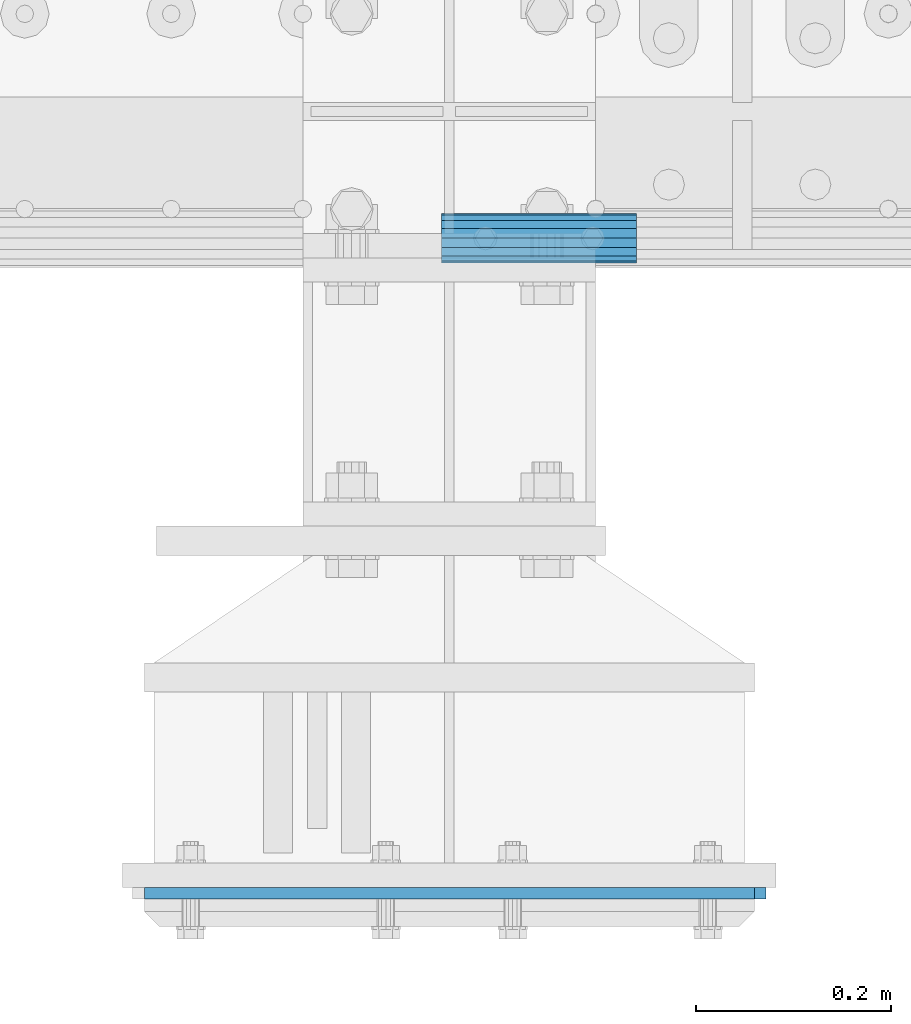
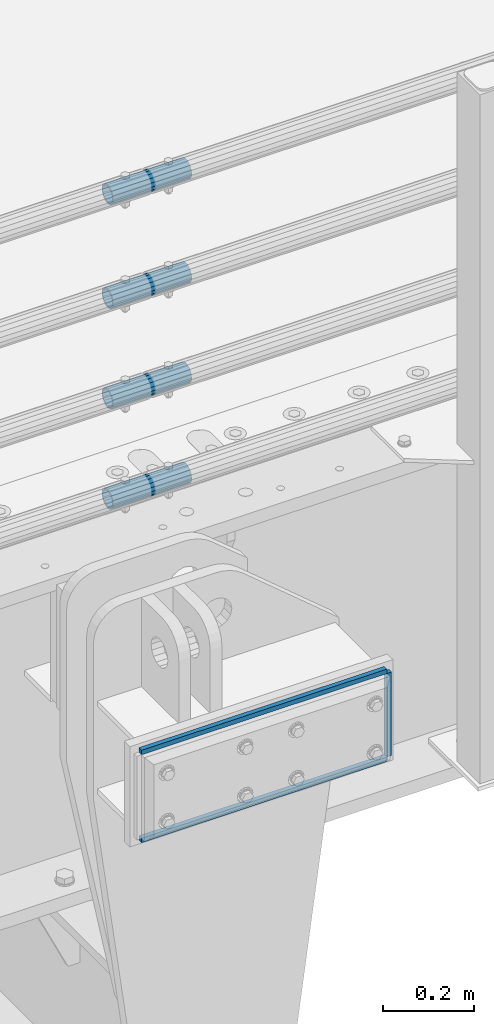
# One storey, part 157 of 270: 7 beams.
"""IFC2X3 building model written with IfcOpenShell, lengths in millimetres."""

from ifc_helpers import new_model, si_unit, frame, origin_with_axes, place, context, subcontext, project, spatial, faceted_brep, material, type_object, element, save


model = new_model("IFC2X3")

# Units and contexts
model_context = context("Model", 3, precision=1e-05, world=origin_with_axes())
body_context = subcontext(model_context, "Body", "Model", "MODEL_VIEW")
ifc_project = project(units=[si_unit("LENGTHUNIT", "METRE", prefix="MILLI"), si_unit("AREAUNIT", "SQUARE_METRE"), si_unit("VOLUMEUNIT", "CUBIC_METRE"), si_unit("MASSUNIT", "GRAM", prefix="KILO"), si_unit("TIMEUNIT", "SECOND"), si_unit("PLANEANGLEUNIT", "RADIAN"), si_unit("SOLIDANGLEUNIT", "STERADIAN"), si_unit("THERMODYNAMICTEMPERATUREUNIT", "DEGREE_CELSIUS"), si_unit("LUMINOUSINTENSITYUNIT", "LUMEN")], contexts=[model_context])

# Site, building, storey
site_placement = place(None, origin_with_axes())
site = spatial("IfcSite", under=ifc_project, at=site_placement, CompositionType="ELEMENT")
building_placement = place(site_placement, origin_with_axes())
building = spatial("IfcBuilding", under=site, at=building_placement, Name="Standard", CompositionType="ELEMENT")
storey_placement = place(building_placement, origin_with_axes())
storey = spatial("IfcBuildingStorey", under=building, at=storey_placement, Name="Undefined", CompositionType="ELEMENT", Elevation=0.0)

# Beams
ifc_material_1 = material()
beam_type_1 = type_object("IfcBeamType", PredefinedType="NOTDEFINED")
beam_1_placement = place(storey_placement, frame((14026.9975029999, -24129.8499999996, 149.849999999726), z_axis=(0.0, 0.0, 1.0), x_axis=(1.0, 0.0, 0.0)))
element("IfcBeam", 1, at=beam_1_placement, inside=storey, type_object=beam_type_1, material=ifc_material_1, context=body_context, shape_type="Brep", body=[
    faceted_brep([(0.0, -21.8999999999996, 0.0), (0.0, -20.232961761998, 8.38076716879547), (200.0, -20.232961761998, 8.38076716879547), (200.0, -21.8999999999996, 0.0), (0.0, -15.4856385079856, 15.4856385079854), (200.0, -15.4856385079856, 15.4856385079854), (0.0, -8.3807671687955, 20.2329617619972), (200.0, -8.3807671687955, 20.2329617619972), (0.0, 0.0, 21.9), (200.0, 0.0, 21.9), (0.0, 8.3807671687955, 20.2329617619972), (200.0, 8.3807671687955, 20.2329617619972), (0.0, 15.4856385079856, 15.4856385079854), (200.0, 15.4856385079856, 15.4856385079854), (0.0, 20.232961761998, 8.38076716879547), (200.0, 20.232961761998, 8.38076716879547), (0.0, 21.8999999999996, 0.0), (200.0, 21.8999999999996, 0.0), (0.0, 20.232961761998, -8.38076716879547), (200.0, 20.232961761998, -8.38076716879547), (0.0, 15.4856385079856, -15.4856385079854), (200.0, 15.4856385079856, -15.4856385079854), (0.0, 8.3807671687955, -20.2329617619972), (200.0, 8.3807671687955, -20.2329617619972), (0.0, 0.0, -21.9), (200.0, 0.0, -21.9), (0.0, -8.3807671687955, -20.2329617619972), (200.0, -8.3807671687955, -20.2329617619972), (0.0, -15.4856385079856, -15.4856385079854), (200.0, -15.4856385079856, -15.4856385079854), (0.0, -20.232961761998, -8.38076716879547), (200.0, -20.232961761998, -8.38076716879547), (0.0, -25.5, 0.0), (0.0, -23.5589280790373, -9.7584275253098), (200.0, -23.5589280790373, -9.7584275253098), (200.0, -25.5, 0.0), (0.0, -18.0312229202573, -18.031222920257), (200.0, -18.0312229202573, -18.031222920257), (0.0, -9.75842752531025, -23.5589280790378), (200.0, -9.75842752531025, -23.5589280790378), (0.0, 0.0, -25.5), (200.0, 0.0, -25.5), (0.0, 9.75842752531025, -23.5589280790378), (200.0, 9.75842752531025, -23.5589280790378), (0.0, 18.0312229202573, -18.031222920257), (200.0, 18.0312229202573, -18.031222920257), (0.0, 23.5589280790373, -9.7584275253098), (200.0, 23.5589280790373, -9.7584275253098), (0.0, 25.5, 0.0), (200.0, 25.5, 0.0), (0.0, 23.5589280790373, 9.7584275253098), (200.0, 23.5589280790373, 9.7584275253098), (0.0, 18.0312229202573, 18.031222920257), (200.0, 18.0312229202573, 18.031222920257), (0.0, 9.75842752531025, 23.5589280790378), (200.0, 9.75842752531025, 23.5589280790378), (0.0, 0.0, 25.5), (200.0, 0.0, 25.5), (0.0, -9.75842752531025, 23.5589280790378), (200.0, -9.75842752531025, 23.5589280790378), (0.0, -18.0312229202573, 18.031222920257), (200.0, -18.0312229202573, 18.031222920257), (0.0, -23.5589280790373, 9.7584275253098), (200.0, -23.5589280790373, 9.7584275253098)], [[[0, 1, 2, 3]], [[1, 4, 5, 2]], [[4, 6, 7, 5]], [[6, 8, 9, 7]], [[8, 10, 11, 9]], [[10, 12, 13, 11]], [[12, 14, 15, 13]], [[14, 16, 17, 15]], [[16, 18, 19, 17]], [[18, 20, 21, 19]], [[20, 22, 23, 21]], [[22, 24, 25, 23]], [[24, 26, 27, 25]], [[26, 28, 29, 27]], [[28, 30, 31, 29]], [[30, 0, 3, 31]], [[32, 33, 34, 35]], [[33, 36, 37, 34]], [[36, 38, 39, 37]], [[38, 40, 41, 39]], [[40, 42, 43, 41]], [[42, 44, 45, 43]], [[44, 46, 47, 45]], [[46, 48, 49, 47]], [[48, 50, 51, 49]], [[50, 52, 53, 51]], [[52, 54, 55, 53]], [[54, 56, 57, 55]], [[56, 58, 59, 57]], [[58, 60, 61, 59]], [[60, 62, 63, 61]], [[62, 32, 35, 63]], [[37, 39, 41, 43, 45, 47, 49, 51, 53, 55, 57, 59, 61, 63, 35, 34], [5, 7, 9, 11, 13, 15, 17, 19, 21, 23, 25, 27, 29, 31, 3, 2]], [[62, 60, 58, 56, 54, 52, 50, 48, 46, 44, 42, 40, 38, 36, 33, 32], [30, 28, 26, 24, 22, 20, 18, 16, 14, 12, 10, 8, 6, 4, 1, 0]]]),
])
beam_2_placement = place(storey_placement, frame((14026.9975029999, -24129.8499999996, 420.149999999725), z_axis=(0.0, 0.0, 1.0), x_axis=(1.0, 0.0, 0.0)))
element("IfcBeam", 2, at=beam_2_placement, inside=storey, type_object=beam_type_1, material=ifc_material_1, context=body_context, shape_type="Brep", body=[
    faceted_brep([(0.0, -21.8999999999996, 0.0), (0.0, -20.232961761998, 8.38076716879547), (200.0, -20.232961761998, 8.38076716879547), (200.0, -21.8999999999996, 0.0), (0.0, -15.4856385079856, 15.4856385079854), (200.0, -15.4856385079856, 15.4856385079854), (0.0, -8.3807671687955, 20.2329617619972), (200.0, -8.3807671687955, 20.2329617619972), (0.0, 0.0, 21.9), (200.0, 0.0, 21.9), (0.0, 8.3807671687955, 20.2329617619972), (200.0, 8.3807671687955, 20.2329617619972), (0.0, 15.4856385079856, 15.4856385079854), (200.0, 15.4856385079856, 15.4856385079854), (0.0, 20.232961761998, 8.38076716879547), (200.0, 20.232961761998, 8.38076716879547), (0.0, 21.8999999999996, 0.0), (200.0, 21.8999999999996, 0.0), (0.0, 20.232961761998, -8.38076716879547), (200.0, 20.232961761998, -8.38076716879547), (0.0, 15.4856385079856, -15.4856385079854), (200.0, 15.4856385079856, -15.4856385079854), (0.0, 8.3807671687955, -20.2329617619972), (200.0, 8.3807671687955, -20.2329617619972), (0.0, 0.0, -21.9), (200.0, 0.0, -21.9), (0.0, -8.3807671687955, -20.2329617619972), (200.0, -8.3807671687955, -20.2329617619972), (0.0, -15.4856385079856, -15.4856385079854), (200.0, -15.4856385079856, -15.4856385079854), (0.0, -20.232961761998, -8.38076716879547), (200.0, -20.232961761998, -8.38076716879547), (0.0, -25.5, 0.0), (0.0, -23.5589280790373, -9.7584275253098), (200.0, -23.5589280790373, -9.7584275253098), (200.0, -25.5, 0.0), (0.0, -18.0312229202573, -18.031222920257), (200.0, -18.0312229202573, -18.031222920257), (0.0, -9.75842752531025, -23.5589280790378), (200.0, -9.75842752531025, -23.5589280790378), (0.0, 0.0, -25.5), (200.0, 0.0, -25.5), (0.0, 9.75842752531025, -23.5589280790378), (200.0, 9.75842752531025, -23.5589280790378), (0.0, 18.0312229202573, -18.031222920257), (200.0, 18.0312229202573, -18.031222920257), (0.0, 23.5589280790373, -9.7584275253098), (200.0, 23.5589280790373, -9.7584275253098), (0.0, 25.5, 0.0), (200.0, 25.5, 0.0), (0.0, 23.5589280790373, 9.7584275253098), (200.0, 23.5589280790373, 9.7584275253098), (0.0, 18.0312229202573, 18.031222920257), (200.0, 18.0312229202573, 18.031222920257), (0.0, 9.75842752531025, 23.5589280790378), (200.0, 9.75842752531025, 23.5589280790378), (0.0, 0.0, 25.5), (200.0, 0.0, 25.5), (0.0, -9.75842752531025, 23.5589280790378), (200.0, -9.75842752531025, 23.5589280790378), (0.0, -18.0312229202573, 18.031222920257), (200.0, -18.0312229202573, 18.031222920257), (0.0, -23.5589280790373, 9.7584275253098), (200.0, -23.5589280790373, 9.7584275253098)], [[[0, 1, 2, 3]], [[1, 4, 5, 2]], [[4, 6, 7, 5]], [[6, 8, 9, 7]], [[8, 10, 11, 9]], [[10, 12, 13, 11]], [[12, 14, 15, 13]], [[14, 16, 17, 15]], [[16, 18, 19, 17]], [[18, 20, 21, 19]], [[20, 22, 23, 21]], [[22, 24, 25, 23]], [[24, 26, 27, 25]], [[26, 28, 29, 27]], [[28, 30, 31, 29]], [[30, 0, 3, 31]], [[32, 33, 34, 35]], [[33, 36, 37, 34]], [[36, 38, 39, 37]], [[38, 40, 41, 39]], [[40, 42, 43, 41]], [[42, 44, 45, 43]], [[44, 46, 47, 45]], [[46, 48, 49, 47]], [[48, 50, 51, 49]], [[50, 52, 53, 51]], [[52, 54, 55, 53]], [[54, 56, 57, 55]], [[56, 58, 59, 57]], [[58, 60, 61, 59]], [[60, 62, 63, 61]], [[62, 32, 35, 63]], [[37, 39, 41, 43, 45, 47, 49, 51, 53, 55, 57, 59, 61, 63, 35, 34], [5, 7, 9, 11, 13, 15, 17, 19, 21, 23, 25, 27, 29, 31, 3, 2]], [[62, 60, 58, 56, 54, 52, 50, 48, 46, 44, 42, 40, 38, 36, 33, 32], [30, 28, 26, 24, 22, 20, 18, 16, 14, 12, 10, 8, 6, 4, 1, 0]]]),
])
beam_3_placement = place(storey_placement, frame((14026.9975029999, -24129.8499999996, 969.849999999726), z_axis=(0.0, 0.0, 1.0), x_axis=(1.0, 0.0, 0.0)))
element("IfcBeam", 3, at=beam_3_placement, inside=storey, type_object=beam_type_1, material=ifc_material_1, context=body_context, shape_type="Brep", body=[
    faceted_brep([(0.0, -21.8999999999996, 0.0), (0.0, -20.232961761998, 8.38076716879547), (200.0, -20.232961761998, 8.38076716879547), (200.0, -21.8999999999996, 0.0), (0.0, -15.4856385079856, 15.4856385079854), (200.0, -15.4856385079856, 15.4856385079854), (0.0, -8.3807671687955, 20.2329617619972), (200.0, -8.3807671687955, 20.2329617619972), (0.0, 0.0, 21.9), (200.0, 0.0, 21.9), (0.0, 8.3807671687955, 20.2329617619972), (200.0, 8.3807671687955, 20.2329617619972), (0.0, 15.4856385079856, 15.4856385079854), (200.0, 15.4856385079856, 15.4856385079854), (0.0, 20.232961761998, 8.38076716879547), (200.0, 20.232961761998, 8.38076716879547), (0.0, 21.8999999999996, 0.0), (200.0, 21.8999999999996, 0.0), (0.0, 20.232961761998, -8.38076716879547), (200.0, 20.232961761998, -8.38076716879547), (0.0, 15.4856385079856, -15.4856385079854), (200.0, 15.4856385079856, -15.4856385079854), (0.0, 8.3807671687955, -20.2329617619972), (200.0, 8.3807671687955, -20.2329617619972), (0.0, 0.0, -21.9), (200.0, 0.0, -21.9), (0.0, -8.3807671687955, -20.2329617619972), (200.0, -8.3807671687955, -20.2329617619972), (0.0, -15.4856385079856, -15.4856385079854), (200.0, -15.4856385079856, -15.4856385079854), (0.0, -20.232961761998, -8.38076716879547), (200.0, -20.232961761998, -8.38076716879547), (0.0, -25.5, 0.0), (0.0, -23.5589280790373, -9.7584275253098), (200.0, -23.5589280790373, -9.7584275253098), (200.0, -25.5, 0.0), (0.0, -18.0312229202573, -18.031222920257), (200.0, -18.0312229202573, -18.031222920257), (0.0, -9.75842752531025, -23.5589280790378), (200.0, -9.75842752531025, -23.5589280790378), (0.0, 0.0, -25.5), (200.0, 0.0, -25.5), (0.0, 9.75842752531025, -23.5589280790378), (200.0, 9.75842752531025, -23.5589280790378), (0.0, 18.0312229202573, -18.031222920257), (200.0, 18.0312229202573, -18.031222920257), (0.0, 23.5589280790373, -9.7584275253098), (200.0, 23.5589280790373, -9.7584275253098), (0.0, 25.5, 0.0), (200.0, 25.5, 0.0), (0.0, 23.5589280790373, 9.7584275253098), (200.0, 23.5589280790373, 9.7584275253098), (0.0, 18.0312229202573, 18.031222920257), (200.0, 18.0312229202573, 18.031222920257), (0.0, 9.75842752531025, 23.5589280790378), (200.0, 9.75842752531025, 23.5589280790378), (0.0, 0.0, 25.5), (200.0, 0.0, 25.5), (0.0, -9.75842752531025, 23.5589280790378), (200.0, -9.75842752531025, 23.5589280790378), (0.0, -18.0312229202573, 18.031222920257), (200.0, -18.0312229202573, 18.031222920257), (0.0, -23.5589280790373, 9.7584275253098), (200.0, -23.5589280790373, 9.7584275253098)], [[[0, 1, 2, 3]], [[1, 4, 5, 2]], [[4, 6, 7, 5]], [[6, 8, 9, 7]], [[8, 10, 11, 9]], [[10, 12, 13, 11]], [[12, 14, 15, 13]], [[14, 16, 17, 15]], [[16, 18, 19, 17]], [[18, 20, 21, 19]], [[20, 22, 23, 21]], [[22, 24, 25, 23]], [[24, 26, 27, 25]], [[26, 28, 29, 27]], [[28, 30, 31, 29]], [[30, 0, 3, 31]], [[32, 33, 34, 35]], [[33, 36, 37, 34]], [[36, 38, 39, 37]], [[38, 40, 41, 39]], [[40, 42, 43, 41]], [[42, 44, 45, 43]], [[44, 46, 47, 45]], [[46, 48, 49, 47]], [[48, 50, 51, 49]], [[50, 52, 53, 51]], [[52, 54, 55, 53]], [[54, 56, 57, 55]], [[56, 58, 59, 57]], [[58, 60, 61, 59]], [[60, 62, 63, 61]], [[62, 32, 35, 63]], [[37, 39, 41, 43, 45, 47, 49, 51, 53, 55, 57, 59, 61, 63, 35, 34], [5, 7, 9, 11, 13, 15, 17, 19, 21, 23, 25, 27, 29, 31, 3, 2]], [[62, 60, 58, 56, 54, 52, 50, 48, 46, 44, 42, 40, 38, 36, 33, 32], [30, 28, 26, 24, 22, 20, 18, 16, 14, 12, 10, 8, 6, 4, 1, 0]]]),
])
beam_4_placement = place(storey_placement, frame((14026.9975029999, -24129.8499999996, 689.849999999726), z_axis=(0.0, 0.0, 1.0), x_axis=(1.0, 0.0, 0.0)))
element("IfcBeam", 4, at=beam_4_placement, inside=storey, type_object=beam_type_1, material=ifc_material_1, context=body_context, shape_type="Brep", body=[
    faceted_brep([(0.0, -21.8999999999996, 0.0), (0.0, -20.232961761998, 8.38076716879547), (200.0, -20.232961761998, 8.38076716879547), (200.0, -21.8999999999996, 0.0), (0.0, -15.4856385079856, 15.4856385079854), (200.0, -15.4856385079856, 15.4856385079854), (0.0, -8.3807671687955, 20.2329617619972), (200.0, -8.3807671687955, 20.2329617619972), (0.0, 0.0, 21.9), (200.0, 0.0, 21.9), (0.0, 8.3807671687955, 20.2329617619972), (200.0, 8.3807671687955, 20.2329617619972), (0.0, 15.4856385079856, 15.4856385079854), (200.0, 15.4856385079856, 15.4856385079854), (0.0, 20.232961761998, 8.38076716879547), (200.0, 20.232961761998, 8.38076716879547), (0.0, 21.8999999999996, 0.0), (200.0, 21.8999999999996, 0.0), (0.0, 20.232961761998, -8.38076716879547), (200.0, 20.232961761998, -8.38076716879547), (0.0, 15.4856385079856, -15.4856385079854), (200.0, 15.4856385079856, -15.4856385079854), (0.0, 8.3807671687955, -20.2329617619972), (200.0, 8.3807671687955, -20.2329617619972), (0.0, 0.0, -21.9), (200.0, 0.0, -21.9), (0.0, -8.3807671687955, -20.2329617619972), (200.0, -8.3807671687955, -20.2329617619972), (0.0, -15.4856385079856, -15.4856385079854), (200.0, -15.4856385079856, -15.4856385079854), (0.0, -20.232961761998, -8.38076716879547), (200.0, -20.232961761998, -8.38076716879547), (0.0, -25.5, 0.0), (0.0, -23.5589280790373, -9.7584275253098), (200.0, -23.5589280790373, -9.7584275253098), (200.0, -25.5, 0.0), (0.0, -18.0312229202573, -18.031222920257), (200.0, -18.0312229202573, -18.031222920257), (0.0, -9.75842752531025, -23.5589280790378), (200.0, -9.75842752531025, -23.5589280790378), (0.0, 0.0, -25.5), (200.0, 0.0, -25.5), (0.0, 9.75842752531025, -23.5589280790378), (200.0, 9.75842752531025, -23.5589280790378), (0.0, 18.0312229202573, -18.031222920257), (200.0, 18.0312229202573, -18.031222920257), (0.0, 23.5589280790373, -9.7584275253098), (200.0, 23.5589280790373, -9.7584275253098), (0.0, 25.5, 0.0), (200.0, 25.5, 0.0), (0.0, 23.5589280790373, 9.7584275253098), (200.0, 23.5589280790373, 9.7584275253098), (0.0, 18.0312229202573, 18.031222920257), (200.0, 18.0312229202573, 18.031222920257), (0.0, 9.75842752531025, 23.5589280790378), (200.0, 9.75842752531025, 23.5589280790378), (0.0, 0.0, 25.5), (200.0, 0.0, 25.5), (0.0, -9.75842752531025, 23.5589280790378), (200.0, -9.75842752531025, 23.5589280790378), (0.0, -18.0312229202573, 18.031222920257), (200.0, -18.0312229202573, 18.031222920257), (0.0, -23.5589280790373, 9.7584275253098), (200.0, -23.5589280790373, 9.7584275253098)], [[[0, 1, 2, 3]], [[1, 4, 5, 2]], [[4, 6, 7, 5]], [[6, 8, 9, 7]], [[8, 10, 11, 9]], [[10, 12, 13, 11]], [[12, 14, 15, 13]], [[14, 16, 17, 15]], [[16, 18, 19, 17]], [[18, 20, 21, 19]], [[20, 22, 23, 21]], [[22, 24, 25, 23]], [[24, 26, 27, 25]], [[26, 28, 29, 27]], [[28, 30, 31, 29]], [[30, 0, 3, 31]], [[32, 33, 34, 35]], [[33, 36, 37, 34]], [[36, 38, 39, 37]], [[38, 40, 41, 39]], [[40, 42, 43, 41]], [[42, 44, 45, 43]], [[44, 46, 47, 45]], [[46, 48, 49, 47]], [[48, 50, 51, 49]], [[50, 52, 53, 51]], [[52, 54, 55, 53]], [[54, 56, 57, 55]], [[56, 58, 59, 57]], [[58, 60, 61, 59]], [[60, 62, 63, 61]], [[62, 32, 35, 63]], [[37, 39, 41, 43, 45, 47, 49, 51, 53, 55, 57, 59, 61, 63, 35, 34], [5, 7, 9, 11, 13, 15, 17, 19, 21, 23, 25, 27, 29, 31, 3, 2]], [[62, 60, 58, 56, 54, 52, 50, 48, 46, 44, 42, 40, 38, 36, 33, 32], [30, 28, 26, 24, 22, 20, 18, 16, 14, 12, 10, 8, 6, 4, 1, 0]]]),
])
ifc_material_2 = material(Name="STEEL/S355N")
beam_type_2 = type_object("IfcBeamType", PredefinedType="NOTDEFINED")
beam_5_placement = place(storey_placement, frame((14353.5000000069, -24801.0000000458, -22.5000182389397), z_axis=(-1.0, 0.0, 0.0), x_axis=(0.0, 0.0, -1.0)))
element("IfcBeam", 5, at=beam_5_placement, inside=storey, type_object=beam_type_2, material=ifc_material_2, context=body_context, shape_type="Brep", body=[
    faceted_brep([(0.0, 6.0, -6.0), (0.0, 6.0, 6.0), (225.0, 6.0, 6.0), (225.0, 6.0, -6.0), (0.0, -6.0, 6.0), (225.0, -6.0, 6.0), (0.0, -6.0, -6.0), (225.0, -6.0, -6.0)], [[[0, 1, 2, 3]], [[1, 4, 5, 2]], [[4, 6, 7, 5]], [[6, 0, 3, 7]], [[5, 7, 3, 2]], [[6, 4, 1, 0]]]),
])
for number, where, z_axis, x_axis in (
    (6, (13722.5000000052, -24801.0000000456, -16.5000182389397), (0.0, 0.0, -1.0), (1.0, 0.0, 0.0)),
    (7, (13722.5000000052, -24801.0000000456, -253.50001823894), (0.0, 0.0, -1.0), (1.0, 0.0, 0.0)),
):
    element("IfcBeam", number, at=place(storey_placement, frame(where, z_axis=z_axis, x_axis=x_axis)), inside=storey, type_object=beam_type_2, material=ifc_material_2, context=body_context, shape_type="Brep", body=[
        faceted_brep([(0.0, 6.0, -6.0), (0.0, 6.0, 6.0), (625.000000001684, 6.0, 6.0), (625.000000001684, 6.0, -6.0), (0.0, -6.0, 6.0), (625.000000001684, -6.0, 6.0), (0.0, -6.0, -6.0), (625.000000001684, -6.0, -6.0)], [[[0, 1, 2, 3]], [[1, 4, 5, 2]], [[4, 6, 7, 5]], [[6, 0, 3, 7]], [[5, 7, 3, 2]], [[6, 4, 1, 0]]]),
    ])

save(model, "model.ifc")
